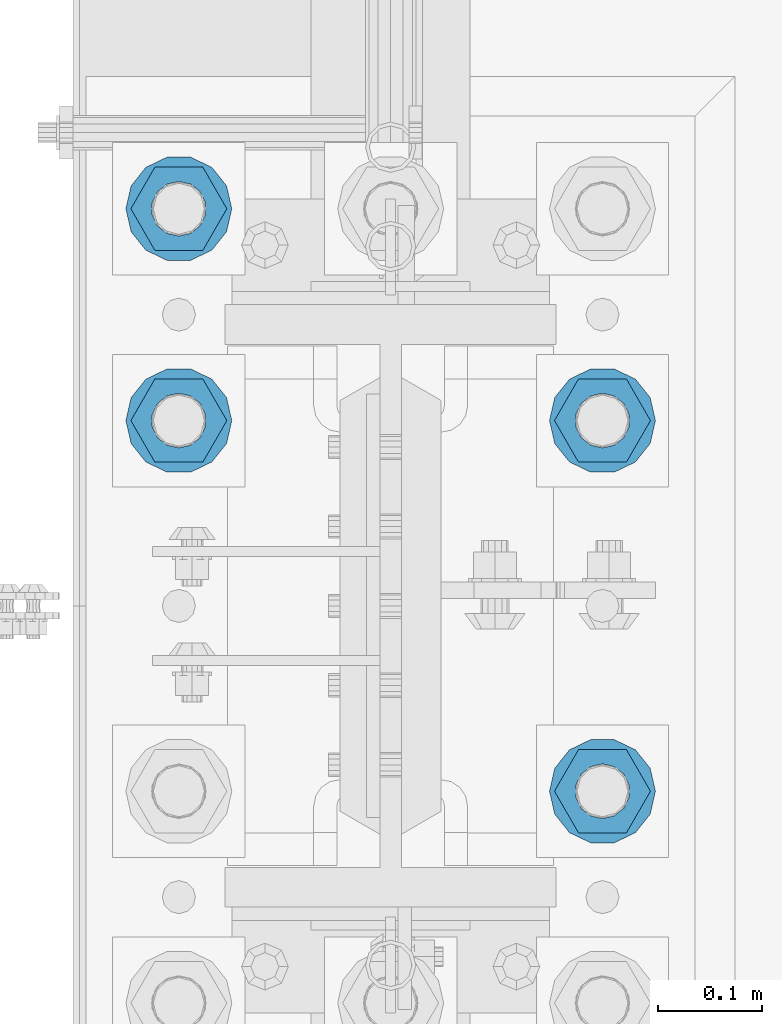
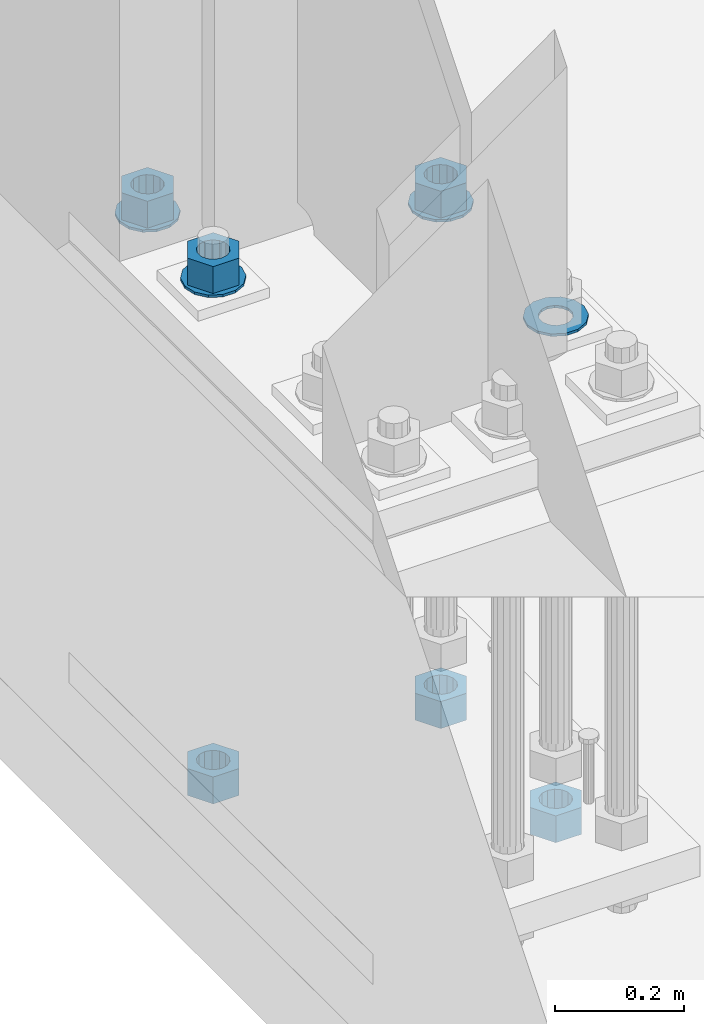
# One storey, part 847 of 1876: 10 columns, 1 element without a shape of its own.
"""IFC2X3 building model written with IfcOpenShell, lengths in millimetres."""

import ifcopenshell
import ifcopenshell.guid

model = None  # the IFC model being written
_history = None  # IfcOwnerHistory: only IFC2X3 demands one
_inside = {}  # id of a spatial element -> (the spatial element, [elements in it])
_under = {}  # id of a project, library or spatial element -> (it, [spatial elements below it])
_declared = {}  # id of a project -> (the project, [libraries it declares])
_typed = {}  # id of a type object -> (the type object, [elements of that type])
_made_of = {}  # id of a material, layer set ... -> (it, [elements and type objects made of it])


def new_model(schema):
    """Start an empty IFC model of exactly this schema.

    Asked for "IFC4X3", IfcOpenShell would pick the latest addendum, in which some entities
    have other attributes; the version numbers below select the first issue.
    IFC2X3 requires an IfcOwnerHistory on every rooted entity: one is made here for all.
    """
    global model, _history
    if schema == "IFC4X3":
        model = ifcopenshell.file(schema_version=(4, 3, 0, 0))
    else:
        model = ifcopenshell.file(schema=schema)
    _inside.clear()
    _under.clear()
    _declared.clear()
    _typed.clear()
    _made_of.clear()
    _history = None
    if model.schema == "IFC2X3":
        org = make("IfcOrganization", Name="unknown")
        user = make(
            "IfcPersonAndOrganization",
            ThePerson=make("IfcPerson", FamilyName="unknown"),
            TheOrganization=org,
        )
        app = make(
            "IfcApplication",
            ApplicationDeveloper=org,
            Version="unknown",
            ApplicationFullName="unknown",
            ApplicationIdentifier="unknown",
        )
        _history = make(
            "IfcOwnerHistory",
            OwningUser=user,
            OwningApplication=app,
            ChangeAction="ADDED",
            CreationDate=0,
        )
    return model


def make(cls, **values):
    """One entity of the class cls with the attributes given. An attribute that is None is left unset."""
    return model.create_entity(
        cls, **{name: value for name, value in values.items() if value is not None}
    )


def rooted(cls, **values):
    """An entity with a GlobalId (a new one), such as an element, a storey or a relation."""
    return make(cls, GlobalId=ifcopenshell.guid.new(), OwnerHistory=_history, **values)


def si_unit(unit_type, name, prefix=None):
    """IfcSIUnit, for example si_unit("LENGTHUNIT", "METRE", prefix="MILLI")."""
    return make("IfcSIUnit", UnitType=unit_type, Prefix=prefix, Name=name)


def assignment(units):
    """IfcUnitAssignment: the units of a project."""
    return None if units is None else make("IfcUnitAssignment", Units=units)


def point(xyz):
    """IfcCartesianPoint."""
    return None if xyz is None else make("IfcCartesianPoint", Coordinates=xyz)


def direction(xyz):
    """IfcDirection."""
    return None if xyz is None else make("IfcDirection", DirectionRatios=xyz)


def frame(location, z_axis=None, x_axis=None):
    """IfcAxis2Placement3D, a coordinate frame: its origin and axes. An axis left out is left unset."""
    return make(
        "IfcAxis2Placement3D",
        Location=point(location),
        Axis=direction(z_axis),
        RefDirection=direction(x_axis),
    )


def origin_with_axes():
    """The frame at (0, 0, 0) with the z axis (0, 0, 1) and the x axis (1, 0, 0) written out."""
    return frame((0.0, 0.0, 0.0), z_axis=(0.0, 0.0, 1.0), x_axis=(1.0, 0.0, 0.0))


def place(relative_to, where):
    """IfcLocalPlacement: puts the frame where relative to a parent placement (None: the world)."""
    return make(
        "IfcLocalPlacement", PlacementRelTo=relative_to, RelativePlacement=where
    )


def context(
    kind, dimensions, precision=None, world=None, true_north=None, identifier=None
):
    """IfcGeometricRepresentationContext, for example the 3D "Model" context."""
    return make(
        "IfcGeometricRepresentationContext",
        ContextIdentifier=identifier,
        ContextType=kind,
        CoordinateSpaceDimension=dimensions,
        Precision=precision,
        WorldCoordinateSystem=world,
        TrueNorth=true_north,
    )


def subcontext(parent, identifier, kind, view, scale=None):
    """IfcGeometricRepresentationSubContext, for example "Body" below "Model"."""
    return make(
        "IfcGeometricRepresentationSubContext",
        ContextIdentifier=identifier,
        ContextType=kind,
        ParentContext=parent,
        TargetScale=scale,
        TargetView=view,
    )


def project(units=None, contexts=None):
    """IfcProject with its units and contexts."""
    return rooted(
        "IfcProject",
        Name="project",
        RepresentationContexts=contexts,
        UnitsInContext=assignment(units),
    )


def spatial(cls, under=None, at=None, **own):
    """A site, building, storey or space (cls), placed at a placement, below another one or the project."""
    s = rooted(cls, ObjectPlacement=at, **own)
    if under is not None:
        _under.setdefault(under.id(), (under, []))[1].append(s)
    return s


def faces_of(points, faces, orient=None, outer=None):
    """IfcFace entities. A face is a list of loops; a loop is a list of indices into points, from 0.

    orient and outer hold one flag for each loop. By default every Orientation is true, the
    first loop of a face is its IfcFaceOuterBound and the others are IfcFaceBound.
    """
    made = []
    for i, loops in enumerate(faces):
        bounds = []
        for j, loop in enumerate(loops):
            is_outer = j == 0 if outer is None else outer[i][j]
            bounds.append(
                make(
                    "IfcFaceOuterBound" if is_outer else "IfcFaceBound",
                    Bound=make("IfcPolyLoop", Polygon=[points[k] for k in loop]),
                    Orientation=True if orient is None else orient[i][j],
                )
            )
        made.append(make("IfcFace", Bounds=bounds))
    return made


def faceted_brep(points, faces, orient=None, outer=None, voids=None):
    """IfcFacetedBrep: a solid bounded by flat faces; with voids (closed shells), ...WithVoids."""
    shared = [point(p) for p in points]
    hull = make("IfcClosedShell", CfsFaces=faces_of(shared, faces, orient, outer))
    if voids is None:
        return make("IfcFacetedBrep", Outer=hull)
    return make(
        "IfcFacetedBrepWithVoids",
        Outer=hull,
        Voids=[
            make(cls, CfsFaces=faces_of(shared, fs, o, b)) for cls, fs, o, b in voids
        ],
    )


def shape(context_of_items, identifier, shape_type, items):
    """IfcShapeRepresentation: the items that make up one representation, for example the "Body"."""
    return make(
        "IfcShapeRepresentation",
        ContextOfItems=context_of_items,
        RepresentationIdentifier=identifier,
        RepresentationType=shape_type,
        Items=items,
    )


def material(Name=None, Category=None):
    """IfcMaterial."""
    return make("IfcMaterial", Name=Name, Category=Category)


def made_of(thing, what):
    """Note that an element or type object is made of a material, layer set ...; save() writes the relation."""
    if what is not None:
        _made_of.setdefault(what.id(), (what, []))[1].append(thing)
    return thing


def type_object(cls, material=None, **own):
    """A type object (cls), such as IfcWallType, which elements share."""
    return made_of(rooted(cls, **own), material)


def element(
    cls,
    number,
    at=None,
    inside=None,
    cuts=None,
    type_object=None,
    material=None,
    context=None,
    identifier="Body",
    shape_type=None,
    held_by="IfcProductDefinitionShape",
    body=None,
    shapes=None,
    **own,
):
    """One element of the class cls, such as IfcWall. Its Tag is "e" and its number.

    at: its placement. inside: the storey or other place that contains it. cuts: it is an
    opening in that element (IfcRelVoidsElement). A single representation is given by context,
    identifier, shape_type and body (its items); several are given by shapes. held_by: the class
    of the entity that holds the representations. save() writes the other relations.
    """
    e = rooted(cls, Tag="e%d" % number, ObjectPlacement=at, **own)
    if body is not None:
        shapes = [shape(context, identifier, shape_type, body)]
    if shapes is not None:
        e.Representation = make(held_by, Representations=shapes)
    if inside is not None:
        _inside.setdefault(inside.id(), (inside, []))[1].append(e)
    if cuts is not None:
        rooted(
            "IfcRelVoidsElement", RelatingBuildingElement=cuts, RelatedOpeningElement=e
        )
    if type_object is not None:
        _typed.setdefault(type_object.id(), (type_object, []))[1].append(e)
    return made_of(e, material)


def aggregate(whole, parts):
    """IfcRelAggregates: a whole, such as a stair, and the parts it consists of."""
    return rooted("IfcRelAggregates", RelatingObject=whole, RelatedObjects=parts)


def save(model, path):
    """Write the relations noted so far, then the file.

    IfcRelAggregates (storeys below a building ...), IfcRelContainedInSpatialStructure (elements
    in a storey), IfcRelDefinesByType, IfcRelAssociatesMaterial and IfcRelDeclares: one each for
    every whole, place, type object, material and project.
    """
    for whole, parts in _under.values():
        aggregate(whole, parts)
    for where, things in _inside.values():
        rooted(
            "IfcRelContainedInSpatialStructure",
            RelatedElements=things,
            RelatingStructure=where,
        )
    for kind, things in _typed.values():
        rooted("IfcRelDefinesByType", RelatedObjects=things, RelatingType=kind)
    for what, things in _made_of.values():
        rooted("IfcRelAssociatesMaterial", RelatedObjects=things, RelatingMaterial=what)
    for by, libraries in _declared.values():
        rooted("IfcRelDeclares", RelatingContext=by, RelatedDefinitions=libraries)
    model.write(path)


model = new_model("IFC2X3")

# Units and contexts
model_context = context("Model", 3, precision=1e-05, world=origin_with_axes())
body_context = subcontext(model_context, "Body", "Model", "MODEL_VIEW")
ifc_project = project(units=[si_unit("LENGTHUNIT", "METRE", prefix="MILLI"), si_unit("AREAUNIT", "SQUARE_METRE"), si_unit("VOLUMEUNIT", "CUBIC_METRE"), si_unit("MASSUNIT", "GRAM", prefix="KILO"), si_unit("TIMEUNIT", "SECOND"), si_unit("PLANEANGLEUNIT", "RADIAN"), si_unit("SOLIDANGLEUNIT", "STERADIAN"), si_unit("THERMODYNAMICTEMPERATUREUNIT", "DEGREE_CELSIUS"), si_unit("LUMINOUSINTENSITYUNIT", "LUMEN")], contexts=[model_context])

# Site, building, storey
site_placement = place(None, origin_with_axes())
site = spatial("IfcSite", under=ifc_project, at=site_placement, CompositionType="ELEMENT")
building_placement = place(site_placement, origin_with_axes())
building = spatial("IfcBuilding", under=site, at=building_placement, Name="Undefined", CompositionType="ELEMENT")
storey_placement = place(building_placement, origin_with_axes())
storey = spatial("IfcBuildingStorey", under=building, at=storey_placement, Name="Undefined", CompositionType="ELEMENT", Elevation=0.0)

# Assembly, columns
assembly_placement = place(storey_placement, origin_with_axes())
assembly = element("IfcElementAssembly", 1, at=assembly_placement, inside=storey, Name="TEMPLATE", AssemblyPlace="NOTDEFINED", PredefinedType="RIGID_FRAME")
ifc_material_1 = material(Name="STEEL/F436")
column_type_1 = type_object("IfcColumnType", Name="2_WASHER", PredefinedType="NOTDEFINED")
column_1_placement = place(assembly_placement, frame((203.2, 7442.2, 119.0625), z_axis=(0.0, 1.0, 0.0), x_axis=(0.0, 0.0, -1.0)))
column_1 = element("IfcColumn", 2, at=column_1_placement, type_object=column_type_1, material=ifc_material_1, Name="WASHER", ObjectType="2_WASHER", context=body_context, shape_type="Brep", body=[
    faceted_brep([(0.0, -50.7999992370605, 9.09494701772928e-13), (0.0, -45.7692178020588, -22.0412936161442), (4.7625, -45.7692178020588, -22.0412936161442), (4.7625, -50.7999992370605, 9.09494701772928e-13), (0.0, -31.6732814587394, -39.7170387128856), (4.7625, -31.6732814587394, -39.7170387128856), (0.0, -11.3040632752118, -49.5263371950259), (4.7625, -11.3040632752118, -49.5263371950259), (0.0, 11.30406327521, -49.5263371950264), (4.7625, 11.30406327521, -49.5263371950264), (0.0, 31.6732814587385, -39.7170387128867), (4.7625, 31.6732814587385, -39.7170387128867), (0.0, 45.7692178020579, -22.041293616146), (4.7625, 45.7692178020579, -22.041293616146), (0.0, 50.7999992370605, -9.09494701772928e-13), (4.7625, 50.7999992370605, -9.09494701772928e-13), (0.0, 45.7692178020588, 22.0412936161442), (4.7625, 45.7692178020588, 22.0412936161442), (0.0, 31.6732814587394, 39.7170387128856), (4.7625, 31.6732814587394, 39.7170387128856), (0.0, 11.3040632752118, 49.5263371950259), (4.7625, 11.3040632752118, 49.5263371950259), (0.0, -11.30406327521, 49.5263371950264), (4.7625, -11.30406327521, 49.5263371950264), (0.0, -31.6732814587385, 39.7170387128867), (4.7625, -31.6732814587385, 39.7170387128867), (0.0, -45.7692178020579, 22.041293616146), (4.7625, -45.7692178020579, 22.041293616146), (0.0, 0.0, 26.9869995117188), (0.0, 11.7093983825444, 24.3146012721213), (4.7625, 11.7093983825444, 24.3146012721213), (4.7625, 0.0, 26.9869995117188), (0.0, 21.0996520289491, 16.8262864224157), (4.7625, 21.0996520289491, 16.8262864224157), (0.0, 26.3108629296712, 6.00524193584533), (4.7625, 26.3108629296712, 6.00524193584533), (0.0, 26.3108629296712, -6.00524193584533), (4.7625, 26.3108629296712, -6.00524193584533), (0.0, 21.0996520289491, -16.8262864224157), (4.7625, 21.0996520289491, -16.8262864224157), (0.0, 11.7093983825444, -24.3146012721213), (4.7625, 11.7093983825444, -24.3146012721213), (0.0, 0.0, -26.9869995117188), (4.7625, 0.0, -26.9869995117188), (0.0, -11.7093983825444, -24.3146012721213), (4.7625, -11.7093983825444, -24.3146012721213), (0.0, -21.0996520289491, -16.8262864224157), (4.7625, -21.0996520289491, -16.8262864224157), (0.0, -26.3108629296712, -6.00524193584533), (4.7625, -26.3108629296712, -6.00524193584533), (0.0, -26.3108629296712, 6.00524193584533), (4.7625, -26.3108629296712, 6.00524193584533), (0.0, -21.0996520289491, 16.8262864224157), (4.7625, -21.0996520289491, 16.8262864224157), (0.0, -11.7093983825444, 24.3146012721213), (4.7625, -11.7093983825444, 24.3146012721213)], [[[0, 1, 2, 3]], [[1, 4, 5, 2]], [[4, 6, 7, 5]], [[6, 8, 9, 7]], [[8, 10, 11, 9]], [[10, 12, 13, 11]], [[12, 14, 15, 13]], [[14, 16, 17, 15]], [[16, 18, 19, 17]], [[18, 20, 21, 19]], [[20, 22, 23, 21]], [[22, 24, 25, 23]], [[24, 26, 27, 25]], [[26, 0, 3, 27]], [[28, 29, 30, 31]], [[29, 32, 33, 30]], [[32, 34, 35, 33]], [[34, 36, 37, 35]], [[36, 38, 39, 37]], [[38, 40, 41, 39]], [[40, 42, 43, 41]], [[42, 44, 45, 43]], [[44, 46, 47, 45]], [[46, 48, 49, 47]], [[48, 50, 51, 49]], [[50, 52, 53, 51]], [[52, 54, 55, 53]], [[54, 28, 31, 55]], [[5, 7, 9, 11, 13, 15, 17, 19, 21, 23, 25, 27, 3, 2], [33, 35, 37, 39, 41, 43, 45, 47, 49, 51, 53, 55, 31, 30]], [[26, 24, 22, 20, 18, 16, 14, 12, 10, 8, 6, 4, 1, 0], [54, 52, 50, 48, 46, 44, 42, 40, 38, 36, 34, 32, 29, 28]]]),
])
column_2_placement = place(assembly_placement, frame((-203.2, 7797.8, 119.0625), z_axis=(0.0, -1.0, 0.0), x_axis=(0.0, 0.0, -1.0)))
column_2 = element("IfcColumn", 3, at=column_2_placement, type_object=column_type_1, material=ifc_material_1, Name="WASHER", ObjectType="2_WASHER", context=body_context, shape_type="Brep", body=[
    faceted_brep([(0.0, -50.7999992370605, 9.09494701772928e-13), (0.0, -45.7692178020588, -22.0412936161442), (4.7625, -45.7692178020588, -22.0412936161442), (4.7625, -50.7999992370605, 9.09494701772928e-13), (0.0, -31.6732814587394, -39.7170387128856), (4.7625, -31.6732814587394, -39.7170387128856), (0.0, -11.3040632752118, -49.5263371950259), (4.7625, -11.3040632752118, -49.5263371950259), (0.0, 11.30406327521, -49.5263371950264), (4.7625, 11.30406327521, -49.5263371950264), (0.0, 31.6732814587385, -39.7170387128867), (4.7625, 31.6732814587385, -39.7170387128867), (0.0, 45.7692178020579, -22.041293616146), (4.7625, 45.7692178020579, -22.041293616146), (0.0, 50.7999992370605, -9.09494701772928e-13), (4.7625, 50.7999992370605, -9.09494701772928e-13), (0.0, 45.7692178020588, 22.0412936161442), (4.7625, 45.7692178020588, 22.0412936161442), (0.0, 31.6732814587394, 39.7170387128856), (4.7625, 31.6732814587394, 39.7170387128856), (0.0, 11.3040632752118, 49.5263371950259), (4.7625, 11.3040632752118, 49.5263371950259), (0.0, -11.30406327521, 49.5263371950264), (4.7625, -11.30406327521, 49.5263371950264), (0.0, -31.6732814587385, 39.7170387128867), (4.7625, -31.6732814587385, 39.7170387128867), (0.0, -45.7692178020579, 22.041293616146), (4.7625, -45.7692178020579, 22.041293616146), (0.0, 0.0, 26.9869995117188), (0.0, 11.7093983825444, 24.3146012721213), (4.7625, 11.7093983825444, 24.3146012721213), (4.7625, 0.0, 26.9869995117188), (0.0, 21.0996520289491, 16.8262864224157), (4.7625, 21.0996520289491, 16.8262864224157), (0.0, 26.3108629296712, 6.00524193584533), (4.7625, 26.3108629296712, 6.00524193584533), (0.0, 26.3108629296712, -6.00524193584533), (4.7625, 26.3108629296712, -6.00524193584533), (0.0, 21.0996520289491, -16.8262864224157), (4.7625, 21.0996520289491, -16.8262864224157), (0.0, 11.7093983825444, -24.3146012721213), (4.7625, 11.7093983825444, -24.3146012721213), (0.0, 0.0, -26.9869995117188), (4.7625, 0.0, -26.9869995117188), (0.0, -11.7093983825444, -24.3146012721213), (4.7625, -11.7093983825444, -24.3146012721213), (0.0, -21.0996520289491, -16.8262864224157), (4.7625, -21.0996520289491, -16.8262864224157), (0.0, -26.3108629296712, -6.00524193584533), (4.7625, -26.3108629296712, -6.00524193584533), (0.0, -26.3108629296712, 6.00524193584533), (4.7625, -26.3108629296712, 6.00524193584533), (0.0, -21.0996520289491, 16.8262864224157), (4.7625, -21.0996520289491, 16.8262864224157), (0.0, -11.7093983825444, 24.3146012721213), (4.7625, -11.7093983825444, 24.3146012721213)], [[[0, 1, 2, 3]], [[1, 4, 5, 2]], [[4, 6, 7, 5]], [[6, 8, 9, 7]], [[8, 10, 11, 9]], [[10, 12, 13, 11]], [[12, 14, 15, 13]], [[14, 16, 17, 15]], [[16, 18, 19, 17]], [[18, 20, 21, 19]], [[20, 22, 23, 21]], [[22, 24, 25, 23]], [[24, 26, 27, 25]], [[26, 0, 3, 27]], [[28, 29, 30, 31]], [[29, 32, 33, 30]], [[32, 34, 35, 33]], [[34, 36, 37, 35]], [[36, 38, 39, 37]], [[38, 40, 41, 39]], [[40, 42, 43, 41]], [[42, 44, 45, 43]], [[44, 46, 47, 45]], [[46, 48, 49, 47]], [[48, 50, 51, 49]], [[50, 52, 53, 51]], [[52, 54, 55, 53]], [[54, 28, 31, 55]], [[5, 7, 9, 11, 13, 15, 17, 19, 21, 23, 25, 27, 3, 2], [33, 35, 37, 39, 41, 43, 45, 47, 49, 51, 53, 55, 31, 30]], [[26, 24, 22, 20, 18, 16, 14, 12, 10, 8, 6, 4, 1, 0], [54, 52, 50, 48, 46, 44, 42, 40, 38, 36, 34, 32, 29, 28]]]),
])
column_3_placement = place(assembly_placement, frame((203.2, 7797.8, 119.0625), z_axis=(0.0, 1.0, 0.0), x_axis=(0.0, 0.0, -1.0)))
column_3 = element("IfcColumn", 4, at=column_3_placement, type_object=column_type_1, material=ifc_material_1, Name="WASHER", ObjectType="2_WASHER", context=body_context, shape_type="Brep", body=[
    faceted_brep([(0.0, -50.7999992370605, 9.09494701772928e-13), (0.0, -45.7692178020588, -22.0412936161442), (4.7625, -45.7692178020588, -22.0412936161442), (4.7625, -50.7999992370605, 9.09494701772928e-13), (0.0, -31.6732814587394, -39.7170387128856), (4.7625, -31.6732814587394, -39.7170387128856), (0.0, -11.3040632752118, -49.5263371950259), (4.7625, -11.3040632752118, -49.5263371950259), (0.0, 11.30406327521, -49.5263371950264), (4.7625, 11.30406327521, -49.5263371950264), (0.0, 31.6732814587385, -39.7170387128867), (4.7625, 31.6732814587385, -39.7170387128867), (0.0, 45.7692178020579, -22.041293616146), (4.7625, 45.7692178020579, -22.041293616146), (0.0, 50.7999992370605, -9.09494701772928e-13), (4.7625, 50.7999992370605, -9.09494701772928e-13), (0.0, 45.7692178020588, 22.0412936161442), (4.7625, 45.7692178020588, 22.0412936161442), (0.0, 31.6732814587394, 39.7170387128856), (4.7625, 31.6732814587394, 39.7170387128856), (0.0, 11.3040632752118, 49.5263371950259), (4.7625, 11.3040632752118, 49.5263371950259), (0.0, -11.30406327521, 49.5263371950264), (4.7625, -11.30406327521, 49.5263371950264), (0.0, -31.6732814587385, 39.7170387128867), (4.7625, -31.6732814587385, 39.7170387128867), (0.0, -45.7692178020579, 22.041293616146), (4.7625, -45.7692178020579, 22.041293616146), (0.0, 0.0, 26.9869995117188), (0.0, 11.7093983825444, 24.3146012721213), (4.7625, 11.7093983825444, 24.3146012721213), (4.7625, 0.0, 26.9869995117188), (0.0, 21.0996520289491, 16.8262864224157), (4.7625, 21.0996520289491, 16.8262864224157), (0.0, 26.3108629296712, 6.00524193584533), (4.7625, 26.3108629296712, 6.00524193584533), (0.0, 26.3108629296712, -6.00524193584533), (4.7625, 26.3108629296712, -6.00524193584533), (0.0, 21.0996520289491, -16.8262864224157), (4.7625, 21.0996520289491, -16.8262864224157), (0.0, 11.7093983825444, -24.3146012721213), (4.7625, 11.7093983825444, -24.3146012721213), (0.0, 0.0, -26.9869995117188), (4.7625, 0.0, -26.9869995117188), (0.0, -11.7093983825444, -24.3146012721213), (4.7625, -11.7093983825444, -24.3146012721213), (0.0, -21.0996520289491, -16.8262864224157), (4.7625, -21.0996520289491, -16.8262864224157), (0.0, -26.3108629296712, -6.00524193584533), (4.7625, -26.3108629296712, -6.00524193584533), (0.0, -26.3108629296712, 6.00524193584533), (4.7625, -26.3108629296712, 6.00524193584533), (0.0, -21.0996520289491, 16.8262864224157), (4.7625, -21.0996520289491, 16.8262864224157), (0.0, -11.7093983825444, 24.3146012721213), (4.7625, -11.7093983825444, 24.3146012721213)], [[[0, 1, 2, 3]], [[1, 4, 5, 2]], [[4, 6, 7, 5]], [[6, 8, 9, 7]], [[8, 10, 11, 9]], [[10, 12, 13, 11]], [[12, 14, 15, 13]], [[14, 16, 17, 15]], [[16, 18, 19, 17]], [[18, 20, 21, 19]], [[20, 22, 23, 21]], [[22, 24, 25, 23]], [[24, 26, 27, 25]], [[26, 0, 3, 27]], [[28, 29, 30, 31]], [[29, 32, 33, 30]], [[32, 34, 35, 33]], [[34, 36, 37, 35]], [[36, 38, 39, 37]], [[38, 40, 41, 39]], [[40, 42, 43, 41]], [[42, 44, 45, 43]], [[44, 46, 47, 45]], [[46, 48, 49, 47]], [[48, 50, 51, 49]], [[50, 52, 53, 51]], [[52, 54, 55, 53]], [[54, 28, 31, 55]], [[5, 7, 9, 11, 13, 15, 17, 19, 21, 23, 25, 27, 3, 2], [33, 35, 37, 39, 41, 43, 45, 47, 49, 51, 53, 55, 31, 30]], [[26, 24, 22, 20, 18, 16, 14, 12, 10, 8, 6, 4, 1, 0], [54, 52, 50, 48, 46, 44, 42, 40, 38, 36, 34, 32, 29, 28]]]),
])
column_4_placement = place(assembly_placement, frame((-203.2, 8001.0, 119.0625), z_axis=(0.0, -1.0, 0.0), x_axis=(0.0, 0.0, -1.0)))
column_4 = element("IfcColumn", 5, at=column_4_placement, type_object=column_type_1, material=ifc_material_1, Name="WASHER", ObjectType="2_WASHER", context=body_context, shape_type="Brep", body=[
    faceted_brep([(0.0, -50.7999992370605, 9.09494701772928e-13), (0.0, -45.7692178020588, -22.0412936161442), (4.7625, -45.7692178020588, -22.0412936161442), (4.7625, -50.7999992370605, 9.09494701772928e-13), (0.0, -31.6732814587394, -39.7170387128856), (4.7625, -31.6732814587394, -39.7170387128856), (0.0, -11.3040632752118, -49.5263371950259), (4.7625, -11.3040632752118, -49.5263371950259), (0.0, 11.30406327521, -49.5263371950264), (4.7625, 11.30406327521, -49.5263371950264), (0.0, 31.6732814587385, -39.7170387128867), (4.7625, 31.6732814587385, -39.7170387128867), (0.0, 45.7692178020579, -22.041293616146), (4.7625, 45.7692178020579, -22.041293616146), (0.0, 50.7999992370605, -9.09494701772928e-13), (4.7625, 50.7999992370605, -9.09494701772928e-13), (0.0, 45.7692178020588, 22.0412936161442), (4.7625, 45.7692178020588, 22.0412936161442), (0.0, 31.6732814587394, 39.7170387128856), (4.7625, 31.6732814587394, 39.7170387128856), (0.0, 11.3040632752118, 49.5263371950259), (4.7625, 11.3040632752118, 49.5263371950259), (0.0, -11.30406327521, 49.5263371950264), (4.7625, -11.30406327521, 49.5263371950264), (0.0, -31.6732814587385, 39.7170387128867), (4.7625, -31.6732814587385, 39.7170387128867), (0.0, -45.7692178020579, 22.041293616146), (4.7625, -45.7692178020579, 22.041293616146), (0.0, 0.0, 26.9869995117188), (0.0, 11.7093983825444, 24.3146012721213), (4.7625, 11.7093983825444, 24.3146012721213), (4.7625, 0.0, 26.9869995117188), (0.0, 21.0996520289491, 16.8262864224157), (4.7625, 21.0996520289491, 16.8262864224157), (0.0, 26.3108629296712, 6.00524193584533), (4.7625, 26.3108629296712, 6.00524193584533), (0.0, 26.3108629296712, -6.00524193584533), (4.7625, 26.3108629296712, -6.00524193584533), (0.0, 21.0996520289491, -16.8262864224157), (4.7625, 21.0996520289491, -16.8262864224157), (0.0, 11.7093983825444, -24.3146012721213), (4.7625, 11.7093983825444, -24.3146012721213), (0.0, 0.0, -26.9869995117188), (4.7625, 0.0, -26.9869995117188), (0.0, -11.7093983825444, -24.3146012721213), (4.7625, -11.7093983825444, -24.3146012721213), (0.0, -21.0996520289491, -16.8262864224157), (4.7625, -21.0996520289491, -16.8262864224157), (0.0, -26.3108629296712, -6.00524193584533), (4.7625, -26.3108629296712, -6.00524193584533), (0.0, -26.3108629296712, 6.00524193584533), (4.7625, -26.3108629296712, 6.00524193584533), (0.0, -21.0996520289491, 16.8262864224157), (4.7625, -21.0996520289491, 16.8262864224157), (0.0, -11.7093983825444, 24.3146012721213), (4.7625, -11.7093983825444, 24.3146012721213)], [[[0, 1, 2, 3]], [[1, 4, 5, 2]], [[4, 6, 7, 5]], [[6, 8, 9, 7]], [[8, 10, 11, 9]], [[10, 12, 13, 11]], [[12, 14, 15, 13]], [[14, 16, 17, 15]], [[16, 18, 19, 17]], [[18, 20, 21, 19]], [[20, 22, 23, 21]], [[22, 24, 25, 23]], [[24, 26, 27, 25]], [[26, 0, 3, 27]], [[28, 29, 30, 31]], [[29, 32, 33, 30]], [[32, 34, 35, 33]], [[34, 36, 37, 35]], [[36, 38, 39, 37]], [[38, 40, 41, 39]], [[40, 42, 43, 41]], [[42, 44, 45, 43]], [[44, 46, 47, 45]], [[46, 48, 49, 47]], [[48, 50, 51, 49]], [[50, 52, 53, 51]], [[52, 54, 55, 53]], [[54, 28, 31, 55]], [[5, 7, 9, 11, 13, 15, 17, 19, 21, 23, 25, 27, 3, 2], [33, 35, 37, 39, 41, 43, 45, 47, 49, 51, 53, 55, 31, 30]], [[26, 24, 22, 20, 18, 16, 14, 12, 10, 8, 6, 4, 1, 0], [54, 52, 50, 48, 46, 44, 42, 40, 38, 36, 34, 32, 29, 28]]]),
])
ifc_material_2 = material(Name="STEEL/A563")
column_type_2 = type_object("IfcColumnType", Name="2_HEAVY_HEX_NUT", PredefinedType="NOTDEFINED")
column_5_placement = place(assembly_placement, frame((203.2, 7442.2, -793.75), z_axis=(0.0, 1.0, 0.0), x_axis=(0.0, 0.0, -1.0)))
column_5 = element("IfcColumn", 6, at=column_5_placement, type_object=column_type_2, material=ifc_material_2, Name="NUT", ObjectType="2_HEAVY_HEX_NUT", context=body_context, shape_type="Brep", body=[
    faceted_brep([(0.0, -46.0369987487793, 9.09494701772928e-13), (0.0, -23.0184993743896, -39.869213104248), (50.8, -23.0184993743896, -39.869213104248), (50.8, -46.0369987487793, 9.09494701772928e-13), (0.0, 23.0184993743896, -39.869213104248), (50.8, 23.0184993743896, -39.869213104248), (0.0, 46.0369987487793, -9.09494701772928e-13), (50.8, 46.0369987487793, -9.09494701772928e-13), (0.0, 23.0184993743896, 39.869213104248), (50.8, 23.0184993743896, 39.869213104248), (0.0, -23.0184993743896, 39.869213104248), (50.8, -23.0184993743896, 39.869213104248), (0.0, 0.0, 26.1940002441406), (0.0, 11.3650617044514, 23.5999013092769), (50.8, 11.3650617044513, 23.5999013092771), (50.8, 0.0, 26.1940002441406), (0.0, 20.4791109456437, 16.3316083006703), (50.8, 20.4791109456439, 16.3316083006703), (0.0, 25.5370200498346, 5.82867859874477), (50.8, 25.5370200498343, 5.82867859874455), (0.0, 25.5370200498346, -5.82867859874477), (50.8, 25.5370200498343, -5.82867859874455), (0.0, 20.4791109456437, -16.3316083006703), (50.8, 20.4791109456439, -16.3316083006703), (0.0, 11.3650617044514, -23.5999013092769), (50.8, 11.3650617044514, -23.5999013092771), (0.0, 0.0, -26.1940002441406), (50.8, 0.0, -26.1940002441406), (0.0, -11.3650617044514, -23.5999013092769), (50.8, -11.3650617044513, -23.5999013092771), (0.0, -20.4791109456437, -16.3316083006703), (50.8, -20.4791109456439, -16.3316083006703), (0.0, -25.5370200498346, -5.82867859874477), (50.8, -25.5370200498343, -5.82867859874455), (0.0, -25.5370200498346, 5.82867859874477), (50.8, -25.5370200498343, 5.82867859874455), (0.0, -20.4791109456437, 16.3316083006703), (50.8, -20.4791109456439, 16.3316083006703), (0.0, -11.3650617044514, 23.5999013092769), (50.8, -11.3650617044514, 23.5999013092771)], [[[0, 1, 2, 3]], [[1, 4, 5, 2]], [[4, 6, 7, 5]], [[6, 8, 9, 7]], [[8, 10, 11, 9]], [[10, 0, 3, 11]], [[12, 13, 14, 15]], [[13, 16, 17, 14]], [[16, 18, 19, 17]], [[18, 20, 21, 19]], [[20, 22, 23, 21]], [[22, 24, 25, 23]], [[24, 26, 27, 25]], [[26, 28, 29, 27]], [[28, 30, 31, 29]], [[30, 32, 33, 31]], [[32, 34, 35, 33]], [[34, 36, 37, 35]], [[36, 38, 39, 37]], [[38, 12, 15, 39]], [[5, 7, 9, 11, 3, 2], [17, 19, 21, 23, 25, 27, 29, 31, 33, 35, 37, 39, 15, 14]], [[10, 8, 6, 4, 1, 0], [38, 36, 34, 32, 30, 28, 26, 24, 22, 20, 18, 16, 13, 12]]]),
])
column_6_placement = place(assembly_placement, frame((-203.2, 7797.8, 169.8625), z_axis=(0.0, -1.0, 0.0), x_axis=(0.0, 0.0, -1.0)))
column_6 = element("IfcColumn", 7, at=column_6_placement, type_object=column_type_2, material=ifc_material_2, Name="NUT", ObjectType="2_HEAVY_HEX_NUT", context=body_context, shape_type="Brep", body=[
    faceted_brep([(0.0, -46.0369987487793, 9.09494701772928e-13), (0.0, -23.0184993743896, -39.869213104248), (50.8, -23.0184993743896, -39.869213104248), (50.8, -46.0369987487793, 9.09494701772928e-13), (0.0, 23.0184993743896, -39.869213104248), (50.8, 23.0184993743896, -39.869213104248), (0.0, 46.0369987487793, -9.09494701772928e-13), (50.8, 46.0369987487793, -9.09494701772928e-13), (0.0, 23.0184993743896, 39.869213104248), (50.8, 23.0184993743896, 39.869213104248), (0.0, -23.0184993743896, 39.869213104248), (50.8, -23.0184993743896, 39.869213104248), (0.0, 0.0, 26.1940002441406), (0.0, 11.3650617044514, 23.5999013092769), (50.8, 11.3650617044513, 23.5999013092771), (50.8, 0.0, 26.1940002441406), (0.0, 20.4791109456437, 16.3316083006703), (50.8, 20.4791109456439, 16.3316083006703), (0.0, 25.5370200498346, 5.82867859874477), (50.8, 25.5370200498343, 5.82867859874455), (0.0, 25.5370200498346, -5.82867859874477), (50.8, 25.5370200498343, -5.82867859874455), (0.0, 20.4791109456437, -16.3316083006703), (50.8, 20.4791109456439, -16.3316083006703), (0.0, 11.3650617044514, -23.5999013092769), (50.8, 11.3650617044514, -23.5999013092771), (0.0, 0.0, -26.1940002441406), (50.8, 0.0, -26.1940002441406), (0.0, -11.3650617044514, -23.5999013092769), (50.8, -11.3650617044513, -23.5999013092771), (0.0, -20.4791109456437, -16.3316083006703), (50.8, -20.4791109456439, -16.3316083006703), (0.0, -25.5370200498346, -5.82867859874477), (50.8, -25.5370200498343, -5.82867859874455), (0.0, -25.5370200498346, 5.82867859874477), (50.8, -25.5370200498343, 5.82867859874455), (0.0, -20.4791109456437, 16.3316083006703), (50.8, -20.4791109456439, 16.3316083006703), (0.0, -11.3650617044514, 23.5999013092769), (50.8, -11.3650617044514, 23.5999013092771)], [[[0, 1, 2, 3]], [[1, 4, 5, 2]], [[4, 6, 7, 5]], [[6, 8, 9, 7]], [[8, 10, 11, 9]], [[10, 0, 3, 11]], [[12, 13, 14, 15]], [[13, 16, 17, 14]], [[16, 18, 19, 17]], [[18, 20, 21, 19]], [[20, 22, 23, 21]], [[22, 24, 25, 23]], [[24, 26, 27, 25]], [[26, 28, 29, 27]], [[28, 30, 31, 29]], [[30, 32, 33, 31]], [[32, 34, 35, 33]], [[34, 36, 37, 35]], [[36, 38, 39, 37]], [[38, 12, 15, 39]], [[5, 7, 9, 11, 3, 2], [17, 19, 21, 23, 25, 27, 29, 31, 33, 35, 37, 39, 15, 14]], [[10, 8, 6, 4, 1, 0], [38, 36, 34, 32, 30, 28, 26, 24, 22, 20, 18, 16, 13, 12]]]),
])
column_7_placement = place(assembly_placement, frame((-203.2, 7797.8, -793.75), z_axis=(0.0, -1.0, 0.0), x_axis=(0.0, 0.0, -1.0)))
column_7 = element("IfcColumn", 8, at=column_7_placement, type_object=column_type_2, material=ifc_material_2, Name="NUT", ObjectType="2_HEAVY_HEX_NUT", context=body_context, shape_type="Brep", body=[
    faceted_brep([(0.0, -46.0369987487793, 9.09494701772928e-13), (0.0, -23.0184993743896, -39.869213104248), (50.8, -23.0184993743896, -39.869213104248), (50.8, -46.0369987487793, 9.09494701772928e-13), (0.0, 23.0184993743896, -39.869213104248), (50.8, 23.0184993743896, -39.869213104248), (0.0, 46.0369987487793, -9.09494701772928e-13), (50.8, 46.0369987487793, -9.09494701772928e-13), (0.0, 23.0184993743896, 39.869213104248), (50.8, 23.0184993743896, 39.869213104248), (0.0, -23.0184993743896, 39.869213104248), (50.8, -23.0184993743896, 39.869213104248), (0.0, 0.0, 26.1940002441406), (0.0, 11.3650617044514, 23.5999013092769), (50.8, 11.3650617044513, 23.5999013092771), (50.8, 0.0, 26.1940002441406), (0.0, 20.4791109456437, 16.3316083006703), (50.8, 20.4791109456439, 16.3316083006703), (0.0, 25.5370200498346, 5.82867859874477), (50.8, 25.5370200498343, 5.82867859874455), (0.0, 25.5370200498346, -5.82867859874477), (50.8, 25.5370200498343, -5.82867859874455), (0.0, 20.4791109456437, -16.3316083006703), (50.8, 20.4791109456439, -16.3316083006703), (0.0, 11.3650617044514, -23.5999013092769), (50.8, 11.3650617044514, -23.5999013092771), (0.0, 0.0, -26.1940002441406), (50.8, 0.0, -26.1940002441406), (0.0, -11.3650617044514, -23.5999013092769), (50.8, -11.3650617044513, -23.5999013092771), (0.0, -20.4791109456437, -16.3316083006703), (50.8, -20.4791109456439, -16.3316083006703), (0.0, -25.5370200498346, -5.82867859874477), (50.8, -25.5370200498343, -5.82867859874455), (0.0, -25.5370200498346, 5.82867859874477), (50.8, -25.5370200498343, 5.82867859874455), (0.0, -20.4791109456437, 16.3316083006703), (50.8, -20.4791109456439, 16.3316083006703), (0.0, -11.3650617044514, 23.5999013092769), (50.8, -11.3650617044514, 23.5999013092771)], [[[0, 1, 2, 3]], [[1, 4, 5, 2]], [[4, 6, 7, 5]], [[6, 8, 9, 7]], [[8, 10, 11, 9]], [[10, 0, 3, 11]], [[12, 13, 14, 15]], [[13, 16, 17, 14]], [[16, 18, 19, 17]], [[18, 20, 21, 19]], [[20, 22, 23, 21]], [[22, 24, 25, 23]], [[24, 26, 27, 25]], [[26, 28, 29, 27]], [[28, 30, 31, 29]], [[30, 32, 33, 31]], [[32, 34, 35, 33]], [[34, 36, 37, 35]], [[36, 38, 39, 37]], [[38, 12, 15, 39]], [[5, 7, 9, 11, 3, 2], [17, 19, 21, 23, 25, 27, 29, 31, 33, 35, 37, 39, 15, 14]], [[10, 8, 6, 4, 1, 0], [38, 36, 34, 32, 30, 28, 26, 24, 22, 20, 18, 16, 13, 12]]]),
])
column_8_placement = place(assembly_placement, frame((203.2, 7797.8, 169.8625), z_axis=(0.0, 1.0, 0.0), x_axis=(0.0, 0.0, -1.0)))
column_8 = element("IfcColumn", 9, at=column_8_placement, type_object=column_type_2, material=ifc_material_2, Name="NUT", ObjectType="2_HEAVY_HEX_NUT", context=body_context, shape_type="Brep", body=[
    faceted_brep([(0.0, -46.0369987487793, 9.09494701772928e-13), (0.0, -23.0184993743896, -39.869213104248), (50.8, -23.0184993743896, -39.869213104248), (50.8, -46.0369987487793, 9.09494701772928e-13), (0.0, 23.0184993743896, -39.869213104248), (50.8, 23.0184993743896, -39.869213104248), (0.0, 46.0369987487793, -9.09494701772928e-13), (50.8, 46.0369987487793, -9.09494701772928e-13), (0.0, 23.0184993743896, 39.869213104248), (50.8, 23.0184993743896, 39.869213104248), (0.0, -23.0184993743896, 39.869213104248), (50.8, -23.0184993743896, 39.869213104248), (0.0, 0.0, 26.1940002441406), (0.0, 11.3650617044514, 23.5999013092769), (50.8, 11.3650617044513, 23.5999013092771), (50.8, 0.0, 26.1940002441406), (0.0, 20.4791109456437, 16.3316083006703), (50.8, 20.4791109456439, 16.3316083006703), (0.0, 25.5370200498346, 5.82867859874477), (50.8, 25.5370200498343, 5.82867859874455), (0.0, 25.5370200498346, -5.82867859874477), (50.8, 25.5370200498343, -5.82867859874455), (0.0, 20.4791109456437, -16.3316083006703), (50.8, 20.4791109456439, -16.3316083006703), (0.0, 11.3650617044514, -23.5999013092769), (50.8, 11.3650617044514, -23.5999013092771), (0.0, 0.0, -26.1940002441406), (50.8, 0.0, -26.1940002441406), (0.0, -11.3650617044514, -23.5999013092769), (50.8, -11.3650617044513, -23.5999013092771), (0.0, -20.4791109456437, -16.3316083006703), (50.8, -20.4791109456439, -16.3316083006703), (0.0, -25.5370200498346, -5.82867859874477), (50.8, -25.5370200498343, -5.82867859874455), (0.0, -25.5370200498346, 5.82867859874477), (50.8, -25.5370200498343, 5.82867859874455), (0.0, -20.4791109456437, 16.3316083006703), (50.8, -20.4791109456439, 16.3316083006703), (0.0, -11.3650617044514, 23.5999013092769), (50.8, -11.3650617044514, 23.5999013092771)], [[[0, 1, 2, 3]], [[1, 4, 5, 2]], [[4, 6, 7, 5]], [[6, 8, 9, 7]], [[8, 10, 11, 9]], [[10, 0, 3, 11]], [[12, 13, 14, 15]], [[13, 16, 17, 14]], [[16, 18, 19, 17]], [[18, 20, 21, 19]], [[20, 22, 23, 21]], [[22, 24, 25, 23]], [[24, 26, 27, 25]], [[26, 28, 29, 27]], [[28, 30, 31, 29]], [[30, 32, 33, 31]], [[32, 34, 35, 33]], [[34, 36, 37, 35]], [[36, 38, 39, 37]], [[38, 12, 15, 39]], [[5, 7, 9, 11, 3, 2], [17, 19, 21, 23, 25, 27, 29, 31, 33, 35, 37, 39, 15, 14]], [[10, 8, 6, 4, 1, 0], [38, 36, 34, 32, 30, 28, 26, 24, 22, 20, 18, 16, 13, 12]]]),
])
column_9_placement = place(assembly_placement, frame((203.2, 7797.8, -793.75), z_axis=(0.0, 1.0, 0.0), x_axis=(0.0, 0.0, -1.0)))
column_9 = element("IfcColumn", 10, at=column_9_placement, type_object=column_type_2, material=ifc_material_2, Name="NUT", ObjectType="2_HEAVY_HEX_NUT", context=body_context, shape_type="Brep", body=[
    faceted_brep([(0.0, -46.0369987487793, 9.09494701772928e-13), (0.0, -23.0184993743896, -39.869213104248), (50.8, -23.0184993743896, -39.869213104248), (50.8, -46.0369987487793, 9.09494701772928e-13), (0.0, 23.0184993743896, -39.869213104248), (50.8, 23.0184993743896, -39.869213104248), (0.0, 46.0369987487793, -9.09494701772928e-13), (50.8, 46.0369987487793, -9.09494701772928e-13), (0.0, 23.0184993743896, 39.869213104248), (50.8, 23.0184993743896, 39.869213104248), (0.0, -23.0184993743896, 39.869213104248), (50.8, -23.0184993743896, 39.869213104248), (0.0, 0.0, 26.1940002441406), (0.0, 11.3650617044514, 23.5999013092769), (50.8, 11.3650617044513, 23.5999013092771), (50.8, 0.0, 26.1940002441406), (0.0, 20.4791109456437, 16.3316083006703), (50.8, 20.4791109456439, 16.3316083006703), (0.0, 25.5370200498346, 5.82867859874477), (50.8, 25.5370200498343, 5.82867859874455), (0.0, 25.5370200498346, -5.82867859874477), (50.8, 25.5370200498343, -5.82867859874455), (0.0, 20.4791109456437, -16.3316083006703), (50.8, 20.4791109456439, -16.3316083006703), (0.0, 11.3650617044514, -23.5999013092769), (50.8, 11.3650617044514, -23.5999013092771), (0.0, 0.0, -26.1940002441406), (50.8, 0.0, -26.1940002441406), (0.0, -11.3650617044514, -23.5999013092769), (50.8, -11.3650617044513, -23.5999013092771), (0.0, -20.4791109456437, -16.3316083006703), (50.8, -20.4791109456439, -16.3316083006703), (0.0, -25.5370200498346, -5.82867859874477), (50.8, -25.5370200498343, -5.82867859874455), (0.0, -25.5370200498346, 5.82867859874477), (50.8, -25.5370200498343, 5.82867859874455), (0.0, -20.4791109456437, 16.3316083006703), (50.8, -20.4791109456439, 16.3316083006703), (0.0, -11.3650617044514, 23.5999013092769), (50.8, -11.3650617044514, 23.5999013092771)], [[[0, 1, 2, 3]], [[1, 4, 5, 2]], [[4, 6, 7, 5]], [[6, 8, 9, 7]], [[8, 10, 11, 9]], [[10, 0, 3, 11]], [[12, 13, 14, 15]], [[13, 16, 17, 14]], [[16, 18, 19, 17]], [[18, 20, 21, 19]], [[20, 22, 23, 21]], [[22, 24, 25, 23]], [[24, 26, 27, 25]], [[26, 28, 29, 27]], [[28, 30, 31, 29]], [[30, 32, 33, 31]], [[32, 34, 35, 33]], [[34, 36, 37, 35]], [[36, 38, 39, 37]], [[38, 12, 15, 39]], [[5, 7, 9, 11, 3, 2], [17, 19, 21, 23, 25, 27, 29, 31, 33, 35, 37, 39, 15, 14]], [[10, 8, 6, 4, 1, 0], [38, 36, 34, 32, 30, 28, 26, 24, 22, 20, 18, 16, 13, 12]]]),
])
column_10_placement = place(assembly_placement, frame((-203.2, 8001.0, 169.8625), z_axis=(0.0, -1.0, 0.0), x_axis=(0.0, 0.0, -1.0)))
column_10 = element("IfcColumn", 11, at=column_10_placement, type_object=column_type_2, material=ifc_material_2, Name="NUT", ObjectType="2_HEAVY_HEX_NUT", context=body_context, shape_type="Brep", body=[
    faceted_brep([(0.0, -46.0369987487793, 9.09494701772928e-13), (0.0, -23.0184993743896, -39.869213104248), (50.8, -23.0184993743896, -39.869213104248), (50.8, -46.0369987487793, 9.09494701772928e-13), (0.0, 23.0184993743896, -39.869213104248), (50.8, 23.0184993743896, -39.869213104248), (0.0, 46.0369987487793, -9.09494701772928e-13), (50.8, 46.0369987487793, -9.09494701772928e-13), (0.0, 23.0184993743896, 39.869213104248), (50.8, 23.0184993743896, 39.869213104248), (0.0, -23.0184993743896, 39.869213104248), (50.8, -23.0184993743896, 39.869213104248), (0.0, 0.0, 26.1940002441406), (0.0, 11.3650617044514, 23.5999013092769), (50.8, 11.3650617044513, 23.5999013092771), (50.8, 0.0, 26.1940002441406), (0.0, 20.4791109456437, 16.3316083006703), (50.8, 20.4791109456439, 16.3316083006703), (0.0, 25.5370200498346, 5.82867859874477), (50.8, 25.5370200498343, 5.82867859874455), (0.0, 25.5370200498346, -5.82867859874477), (50.8, 25.5370200498343, -5.82867859874455), (0.0, 20.4791109456437, -16.3316083006703), (50.8, 20.4791109456439, -16.3316083006703), (0.0, 11.3650617044514, -23.5999013092769), (50.8, 11.3650617044514, -23.5999013092771), (0.0, 0.0, -26.1940002441406), (50.8, 0.0, -26.1940002441406), (0.0, -11.3650617044514, -23.5999013092769), (50.8, -11.3650617044513, -23.5999013092771), (0.0, -20.4791109456437, -16.3316083006703), (50.8, -20.4791109456439, -16.3316083006703), (0.0, -25.5370200498346, -5.82867859874477), (50.8, -25.5370200498343, -5.82867859874455), (0.0, -25.5370200498346, 5.82867859874477), (50.8, -25.5370200498343, 5.82867859874455), (0.0, -20.4791109456437, 16.3316083006703), (50.8, -20.4791109456439, 16.3316083006703), (0.0, -11.3650617044514, 23.5999013092769), (50.8, -11.3650617044514, 23.5999013092771)], [[[0, 1, 2, 3]], [[1, 4, 5, 2]], [[4, 6, 7, 5]], [[6, 8, 9, 7]], [[8, 10, 11, 9]], [[10, 0, 3, 11]], [[12, 13, 14, 15]], [[13, 16, 17, 14]], [[16, 18, 19, 17]], [[18, 20, 21, 19]], [[20, 22, 23, 21]], [[22, 24, 25, 23]], [[24, 26, 27, 25]], [[26, 28, 29, 27]], [[28, 30, 31, 29]], [[30, 32, 33, 31]], [[32, 34, 35, 33]], [[34, 36, 37, 35]], [[36, 38, 39, 37]], [[38, 12, 15, 39]], [[5, 7, 9, 11, 3, 2], [17, 19, 21, 23, 25, 27, 29, 31, 33, 35, 37, 39, 15, 14]], [[10, 8, 6, 4, 1, 0], [38, 36, 34, 32, 30, 28, 26, 24, 22, 20, 18, 16, 13, 12]]]),
])
aggregate(assembly, [column_1, column_5, column_6, column_2, column_7, column_8, column_3, column_9, column_10, column_4])

save(model, "model.ifc")
